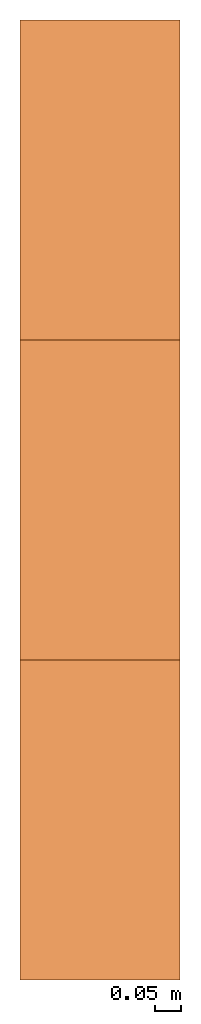
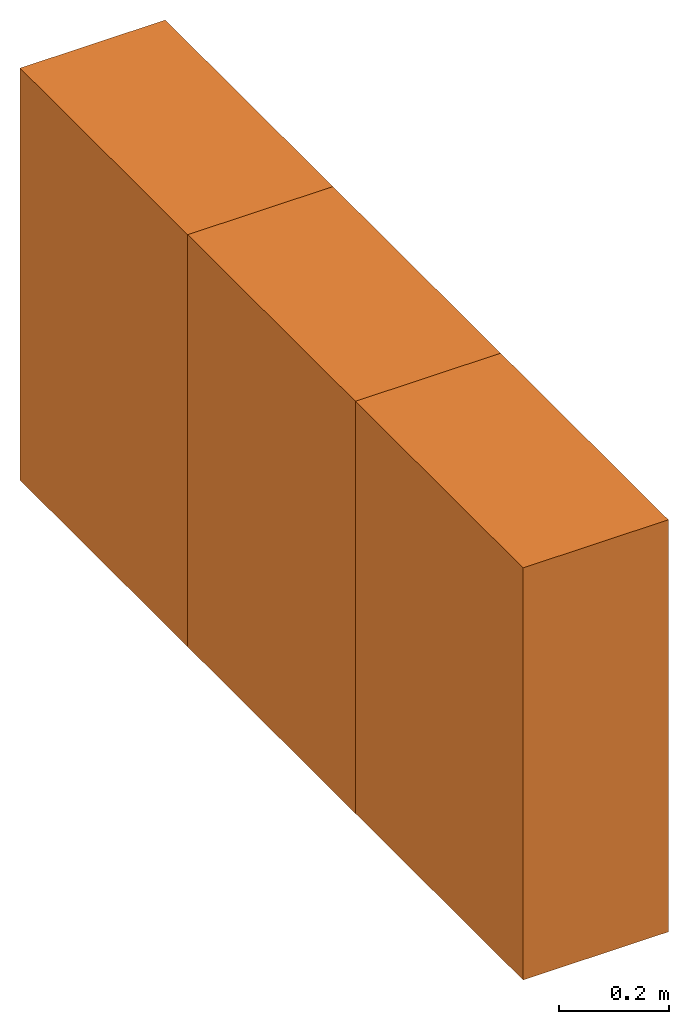
# One storey: 3 proxies.
"""IFC2X3 building model written with IfcOpenShell, lengths in feet."""

from ifc_helpers import new_model, entity, si_unit, converted_unit, derived_unit, direction, frame, frame_2d, origin, origin_2d_with_axis, place, context, subcontext, project, spatial, rectangle, extrude, source, transform, mapped, type_object, type_shapes, element, save


model = new_model("IFC2X3")

# Units and contexts
model_context = context("Model", 3, precision=0.0001, world=origin(), true_north=direction((6.12303176911189e-17, 1.0)))
body_context = subcontext(model_context, "Body", "Model", "MODEL_VIEW")
ifc_project = project(units=[converted_unit("LENGTHUNIT", "FOOT", entity("IfcRatioMeasure", 0.3048), si_unit("LENGTHUNIT", "METRE"), dimensions=[1, 0, 0, 0, 0, 0, 0]), converted_unit("AREAUNIT", "SQUARE FOOT", entity("IfcRatioMeasure", 0.09290304), si_unit("AREAUNIT", "SQUARE_METRE"), dimensions=[2, 0, 0, 0, 0, 0, 0]), converted_unit("VOLUMEUNIT", "CUBIC FOOT", entity("IfcRatioMeasure", 0.028316846592), si_unit("VOLUMEUNIT", "CUBIC_METRE"), dimensions=[3, 0, 0, 0, 0, 0, 0]), converted_unit("PLANEANGLEUNIT", "DEGREE", entity("IfcRatioMeasure", 0.0174532925199433), si_unit("PLANEANGLEUNIT", "RADIAN"), dimensions=[0, 0, 0, 0, 0, 0, 0]), si_unit("MASSUNIT", "GRAM", prefix="KILO"), derived_unit("MASSDENSITYUNIT", [(si_unit("MASSUNIT", "GRAM", prefix="KILO"), 1), (si_unit("LENGTHUNIT", "METRE"), -3)]), si_unit("TIMEUNIT", "SECOND"), si_unit("FREQUENCYUNIT", "HERTZ"), si_unit("THERMODYNAMICTEMPERATUREUNIT", "DEGREE_CELSIUS"), derived_unit("THERMALTRANSMITTANCEUNIT", [(si_unit("MASSUNIT", "GRAM", prefix="KILO"), 1), (si_unit("THERMODYNAMICTEMPERATUREUNIT", "KELVIN"), -1), (si_unit("TIMEUNIT", "SECOND"), -3)]), derived_unit("VOLUMETRICFLOWRATEUNIT", [(si_unit("LENGTHUNIT", "METRE"), 3), (si_unit("TIMEUNIT", "SECOND"), -1)]), si_unit("ELECTRICCURRENTUNIT", "AMPERE"), si_unit("ELECTRICVOLTAGEUNIT", "VOLT"), si_unit("POWERUNIT", "WATT"), si_unit("FORCEUNIT", "NEWTON"), si_unit("ILLUMINANCEUNIT", "LUX"), si_unit("LUMINOUSFLUXUNIT", "LUMEN"), si_unit("LUMINOUSINTENSITYUNIT", "CANDELA"), derived_unit("USERDEFINED", [(si_unit("MASSUNIT", "GRAM", prefix="KILO"), -1), (si_unit("LENGTHUNIT", "METRE"), -2), (si_unit("TIMEUNIT", "SECOND"), 3), (si_unit("LUMINOUSFLUXUNIT", "LUMEN"), 1)]), derived_unit("LINEARVELOCITYUNIT", [(si_unit("LENGTHUNIT", "METRE"), 1), (si_unit("TIMEUNIT", "SECOND"), -1)]), si_unit("PRESSUREUNIT", "PASCAL"), derived_unit("USERDEFINED", [(si_unit("LENGTHUNIT", "METRE"), -2), (si_unit("MASSUNIT", "GRAM", prefix="KILO"), 1), (si_unit("TIMEUNIT", "SECOND"), -2)])], contexts=[model_context])

# Site, building, storey
site_placement = place(None, origin())
site = spatial("IfcSite", under=ifc_project, at=site_placement, CompositionType="ELEMENT")
building_placement = place(site_placement, origin())
building = spatial("IfcBuilding", under=site, at=building_placement, CompositionType="ELEMENT")
storey_placement = place(building_placement, origin())
storey = spatial("IfcBuildingStorey", under=building, at=storey_placement, Name="Level 1", CompositionType="ELEMENT", Elevation=0.0)

# Proxies
building_element_proxy_type_1 = type_object("IfcBuildingElementProxyType", Name="IPF", PredefinedType="NOTDEFINED")
shared_shape_1 = source(origin(), body_context, "Body", "SweptSolid", [
    extrude(rectangle(XDim=2.0, YDim=1.0, at=frame_2d((0.0, 1.11022302462516e-16), x_axis=(1.0, 0.0))), frame((0.500000000000003, 1.0, 0.0), z_axis=(0.0, 0.0, 1.0), x_axis=(0.0, 1.0, 0.0)), (0.0, 0.0, 1.0), 3.0),
])
type_shapes(building_element_proxy_type_1, [shared_shape_1])
proxy_1_placement = place(storey_placement, origin())
element("IfcBuildingElementProxy", 1, at=proxy_1_placement, inside=storey, type_object=building_element_proxy_type_1, ObjectType="IPF", context=body_context, shape_type="MappedRepresentation", body=[
    mapped(shared_shape_1, transform((0.0, 0.0, 0.0), scale=1.0)),
])
building_element_proxy_type_2 = type_object("IfcBuildingElementProxyType", Name="IPF", PredefinedType="NOTDEFINED")
shared_shape_2 = source(origin(), body_context, "Body", "SweptSolid", [
    extrude(rectangle(XDim=2.0, YDim=1.0, at=origin_2d_with_axis()), frame((0.500000000000006, 3.0, 0.0), z_axis=(0.0, 0.0, 1.0), x_axis=(0.0, 1.0, 0.0)), (0.0, 0.0, 1.0), 3.0),
])
type_shapes(building_element_proxy_type_2, [shared_shape_2])
proxy_2_placement = place(storey_placement, origin())
element("IfcBuildingElementProxy", 2, at=proxy_2_placement, inside=storey, type_object=building_element_proxy_type_2, Name="IPF1", ObjectType="IPF", context=body_context, shape_type="MappedRepresentation", body=[
    mapped(shared_shape_2, transform((0.0, 0.0, 0.0), scale=1.0)),
])
building_element_proxy_type_3 = type_object("IfcBuildingElementProxyType", Name="IPF", PredefinedType="NOTDEFINED")
shared_shape_3 = source(origin(), body_context, "Body", "SweptSolid", [
    extrude(rectangle(XDim=2.0, YDim=1.0, at=origin_2d_with_axis()), frame((0.50000000000001, 5.0, 0.0), z_axis=(0.0, 0.0, 1.0), x_axis=(0.0, 1.0, 0.0)), (0.0, 0.0, 1.0), 3.0),
])
type_shapes(building_element_proxy_type_3, [shared_shape_3])
proxy_3_placement = place(storey_placement, origin())
element("IfcBuildingElementProxy", 3, at=proxy_3_placement, inside=storey, type_object=building_element_proxy_type_3, Name="IPF2", ObjectType="IPF", context=body_context, shape_type="MappedRepresentation", body=[
    mapped(shared_shape_3, transform((0.0, 0.0, 0.0), scale=1.0)),
])

save(model, "model.ifc")
